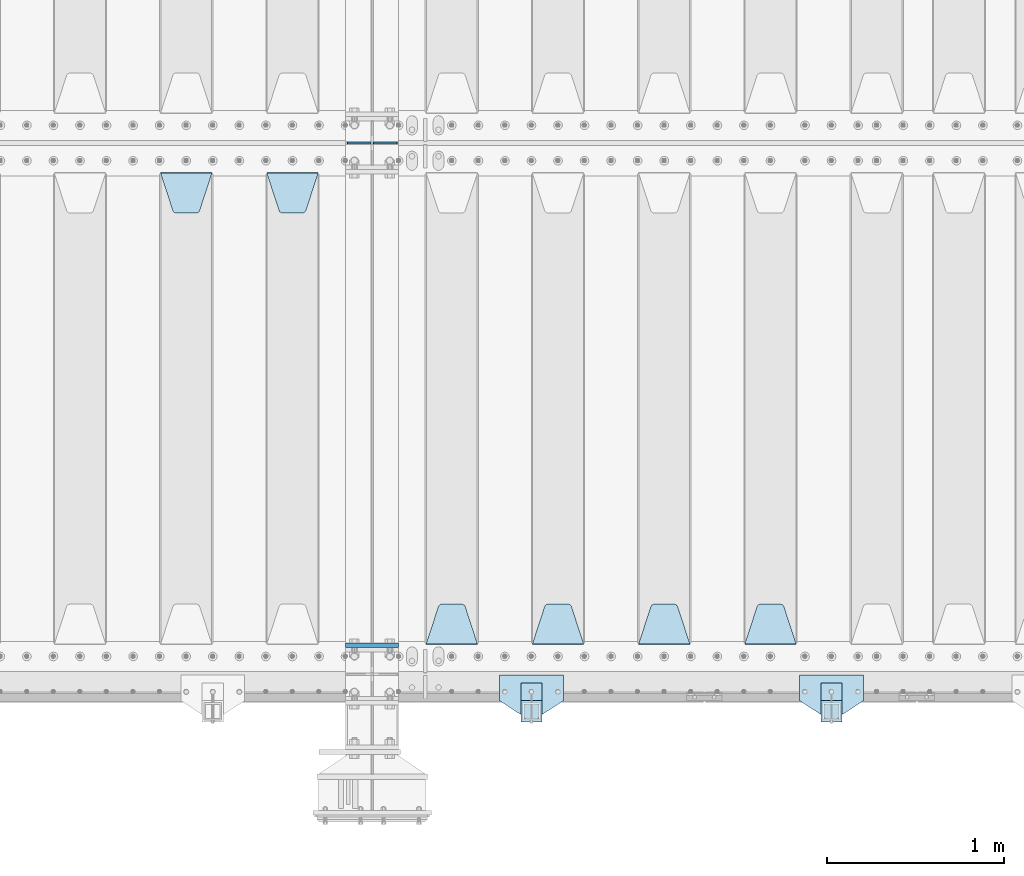
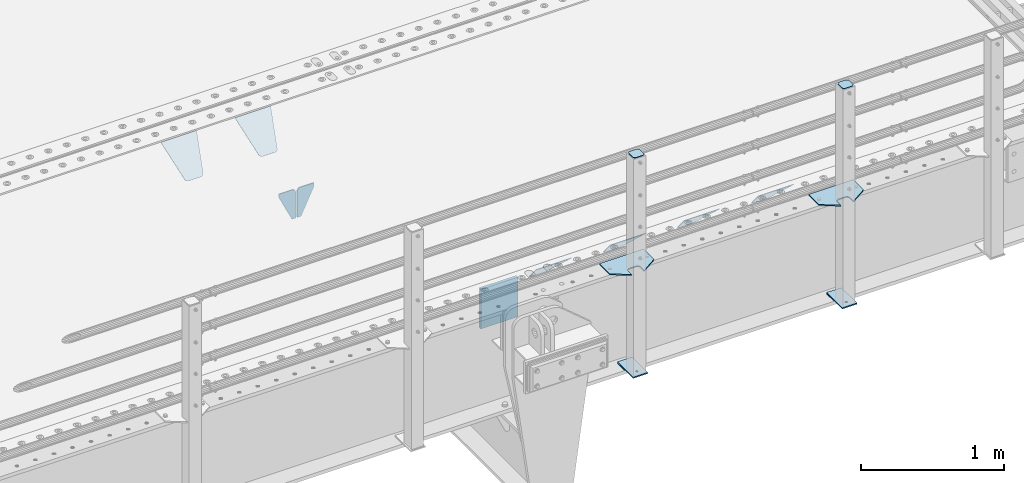
# One storey, part 212 of 257: 17 plates.
"""IFC2X3 building model written with IfcOpenShell, lengths in millimetres."""

import ifcopenshell
import ifcopenshell.guid

model = None  # the IFC model being written
_history = None  # IfcOwnerHistory: only IFC2X3 demands one
_inside = {}  # id of a spatial element -> (the spatial element, [elements in it])
_under = {}  # id of a project, library or spatial element -> (it, [spatial elements below it])
_declared = {}  # id of a project -> (the project, [libraries it declares])
_typed = {}  # id of a type object -> (the type object, [elements of that type])
_made_of = {}  # id of a material, layer set ... -> (it, [elements and type objects made of it])


def new_model(schema):
    """Start an empty IFC model of exactly this schema.

    Asked for "IFC4X3", IfcOpenShell would pick the latest addendum, in which some entities
    have other attributes; the version numbers below select the first issue.
    IFC2X3 requires an IfcOwnerHistory on every rooted entity: one is made here for all.
    """
    global model, _history
    if schema == "IFC4X3":
        model = ifcopenshell.file(schema_version=(4, 3, 0, 0))
    else:
        model = ifcopenshell.file(schema=schema)
    _inside.clear()
    _under.clear()
    _declared.clear()
    _typed.clear()
    _made_of.clear()
    _history = None
    if model.schema == "IFC2X3":
        org = make("IfcOrganization", Name="unknown")
        user = make(
            "IfcPersonAndOrganization",
            ThePerson=make("IfcPerson", FamilyName="unknown"),
            TheOrganization=org,
        )
        app = make(
            "IfcApplication",
            ApplicationDeveloper=org,
            Version="unknown",
            ApplicationFullName="unknown",
            ApplicationIdentifier="unknown",
        )
        _history = make(
            "IfcOwnerHistory",
            OwningUser=user,
            OwningApplication=app,
            ChangeAction="ADDED",
            CreationDate=0,
        )
    return model


def make(cls, **values):
    """One entity of the class cls with the attributes given. An attribute that is None is left unset."""
    return model.create_entity(
        cls, **{name: value for name, value in values.items() if value is not None}
    )


def rooted(cls, **values):
    """An entity with a GlobalId (a new one), such as an element, a storey or a relation."""
    return make(cls, GlobalId=ifcopenshell.guid.new(), OwnerHistory=_history, **values)


def si_unit(unit_type, name, prefix=None):
    """IfcSIUnit, for example si_unit("LENGTHUNIT", "METRE", prefix="MILLI")."""
    return make("IfcSIUnit", UnitType=unit_type, Prefix=prefix, Name=name)


def assignment(units):
    """IfcUnitAssignment: the units of a project."""
    return None if units is None else make("IfcUnitAssignment", Units=units)


def point(xyz):
    """IfcCartesianPoint."""
    return None if xyz is None else make("IfcCartesianPoint", Coordinates=xyz)


def direction(xyz):
    """IfcDirection."""
    return None if xyz is None else make("IfcDirection", DirectionRatios=xyz)


def frame(location, z_axis=None, x_axis=None):
    """IfcAxis2Placement3D, a coordinate frame: its origin and axes. An axis left out is left unset."""
    return make(
        "IfcAxis2Placement3D",
        Location=point(location),
        Axis=direction(z_axis),
        RefDirection=direction(x_axis),
    )


def origin_with_axes():
    """The frame at (0, 0, 0) with the z axis (0, 0, 1) and the x axis (1, 0, 0) written out."""
    return frame((0.0, 0.0, 0.0), z_axis=(0.0, 0.0, 1.0), x_axis=(1.0, 0.0, 0.0))


def place(relative_to, where):
    """IfcLocalPlacement: puts the frame where relative to a parent placement (None: the world)."""
    return make(
        "IfcLocalPlacement", PlacementRelTo=relative_to, RelativePlacement=where
    )


def context(
    kind, dimensions, precision=None, world=None, true_north=None, identifier=None
):
    """IfcGeometricRepresentationContext, for example the 3D "Model" context."""
    return make(
        "IfcGeometricRepresentationContext",
        ContextIdentifier=identifier,
        ContextType=kind,
        CoordinateSpaceDimension=dimensions,
        Precision=precision,
        WorldCoordinateSystem=world,
        TrueNorth=true_north,
    )


def subcontext(parent, identifier, kind, view, scale=None):
    """IfcGeometricRepresentationSubContext, for example "Body" below "Model"."""
    return make(
        "IfcGeometricRepresentationSubContext",
        ContextIdentifier=identifier,
        ContextType=kind,
        ParentContext=parent,
        TargetScale=scale,
        TargetView=view,
    )


def project(units=None, contexts=None):
    """IfcProject with its units and contexts."""
    return rooted(
        "IfcProject",
        Name="project",
        RepresentationContexts=contexts,
        UnitsInContext=assignment(units),
    )


def spatial(cls, under=None, at=None, **own):
    """A site, building, storey or space (cls), placed at a placement, below another one or the project."""
    s = rooted(cls, ObjectPlacement=at, **own)
    if under is not None:
        _under.setdefault(under.id(), (under, []))[1].append(s)
    return s


def faces_of(points, faces, orient=None, outer=None):
    """IfcFace entities. A face is a list of loops; a loop is a list of indices into points, from 0.

    orient and outer hold one flag for each loop. By default every Orientation is true, the
    first loop of a face is its IfcFaceOuterBound and the others are IfcFaceBound.
    """
    made = []
    for i, loops in enumerate(faces):
        bounds = []
        for j, loop in enumerate(loops):
            is_outer = j == 0 if outer is None else outer[i][j]
            bounds.append(
                make(
                    "IfcFaceOuterBound" if is_outer else "IfcFaceBound",
                    Bound=make("IfcPolyLoop", Polygon=[points[k] for k in loop]),
                    Orientation=True if orient is None else orient[i][j],
                )
            )
        made.append(make("IfcFace", Bounds=bounds))
    return made


def faceted_brep(points, faces, orient=None, outer=None, voids=None):
    """IfcFacetedBrep: a solid bounded by flat faces; with voids (closed shells), ...WithVoids."""
    shared = [point(p) for p in points]
    hull = make("IfcClosedShell", CfsFaces=faces_of(shared, faces, orient, outer))
    if voids is None:
        return make("IfcFacetedBrep", Outer=hull)
    return make(
        "IfcFacetedBrepWithVoids",
        Outer=hull,
        Voids=[
            make(cls, CfsFaces=faces_of(shared, fs, o, b)) for cls, fs, o, b in voids
        ],
    )


def shape(context_of_items, identifier, shape_type, items):
    """IfcShapeRepresentation: the items that make up one representation, for example the "Body"."""
    return make(
        "IfcShapeRepresentation",
        ContextOfItems=context_of_items,
        RepresentationIdentifier=identifier,
        RepresentationType=shape_type,
        Items=items,
    )


def material(Name=None, Category=None):
    """IfcMaterial."""
    return make("IfcMaterial", Name=Name, Category=Category)


def made_of(thing, what):
    """Note that an element or type object is made of a material, layer set ...; save() writes the relation."""
    if what is not None:
        _made_of.setdefault(what.id(), (what, []))[1].append(thing)
    return thing


def type_object(cls, material=None, **own):
    """A type object (cls), such as IfcWallType, which elements share."""
    return made_of(rooted(cls, **own), material)


def element(
    cls,
    number,
    at=None,
    inside=None,
    cuts=None,
    type_object=None,
    material=None,
    context=None,
    identifier="Body",
    shape_type=None,
    held_by="IfcProductDefinitionShape",
    body=None,
    shapes=None,
    **own,
):
    """One element of the class cls, such as IfcWall. Its Tag is "e" and its number.

    at: its placement. inside: the storey or other place that contains it. cuts: it is an
    opening in that element (IfcRelVoidsElement). A single representation is given by context,
    identifier, shape_type and body (its items); several are given by shapes. held_by: the class
    of the entity that holds the representations. save() writes the other relations.
    """
    e = rooted(cls, Tag="e%d" % number, ObjectPlacement=at, **own)
    if body is not None:
        shapes = [shape(context, identifier, shape_type, body)]
    if shapes is not None:
        e.Representation = make(held_by, Representations=shapes)
    if inside is not None:
        _inside.setdefault(inside.id(), (inside, []))[1].append(e)
    if cuts is not None:
        rooted(
            "IfcRelVoidsElement", RelatingBuildingElement=cuts, RelatedOpeningElement=e
        )
    if type_object is not None:
        _typed.setdefault(type_object.id(), (type_object, []))[1].append(e)
    return made_of(e, material)


def aggregate(whole, parts):
    """IfcRelAggregates: a whole, such as a stair, and the parts it consists of."""
    return rooted("IfcRelAggregates", RelatingObject=whole, RelatedObjects=parts)


def save(model, path):
    """Write the relations noted so far, then the file.

    IfcRelAggregates (storeys below a building ...), IfcRelContainedInSpatialStructure (elements
    in a storey), IfcRelDefinesByType, IfcRelAssociatesMaterial and IfcRelDeclares: one each for
    every whole, place, type object, material and project.
    """
    for whole, parts in _under.values():
        aggregate(whole, parts)
    for where, things in _inside.values():
        rooted(
            "IfcRelContainedInSpatialStructure",
            RelatedElements=things,
            RelatingStructure=where,
        )
    for kind, things in _typed.values():
        rooted("IfcRelDefinesByType", RelatedObjects=things, RelatingType=kind)
    for what, things in _made_of.values():
        rooted("IfcRelAssociatesMaterial", RelatedObjects=things, RelatingMaterial=what)
    for by, libraries in _declared.values():
        rooted("IfcRelDeclares", RelatingContext=by, RelatedDefinitions=libraries)
    model.write(path)


model = new_model("IFC2X3")

# Units and contexts
model_context = context("Model", 3, precision=1e-05, world=origin_with_axes())
body_context = subcontext(model_context, "Body", "Model", "MODEL_VIEW")
ifc_project = project(units=[si_unit("LENGTHUNIT", "METRE", prefix="MILLI"), si_unit("AREAUNIT", "SQUARE_METRE"), si_unit("VOLUMEUNIT", "CUBIC_METRE"), si_unit("MASSUNIT", "GRAM", prefix="KILO"), si_unit("TIMEUNIT", "SECOND"), si_unit("PLANEANGLEUNIT", "RADIAN"), si_unit("SOLIDANGLEUNIT", "STERADIAN"), si_unit("THERMODYNAMICTEMPERATUREUNIT", "DEGREE_CELSIUS"), si_unit("LUMINOUSINTENSITYUNIT", "LUMEN")], contexts=[model_context])

# Site, building, storey
site_placement = place(None, origin_with_axes())
site = spatial("IfcSite", under=ifc_project, at=site_placement, CompositionType="ELEMENT")
building_placement = place(site_placement, origin_with_axes())
building = spatial("IfcBuilding", under=site, at=building_placement, Name="Standard", CompositionType="ELEMENT")
storey_placement = place(building_placement, origin_with_axes())
storey = spatial("IfcBuildingStorey", under=building, at=storey_placement, Name="Undefined", CompositionType="ELEMENT", Elevation=0.0)

# Plates
ifc_material_1 = material(Name="STEEL/S355N")
plate_type_1 = type_object("IfcPlateType", PredefinedType="NOTDEFINED")
plate_1_placement = place(storey_placement, frame((54550.0, 162.5, -340.000000000044), z_axis=(0.0, 0.0, 1.0), x_axis=(1.0, 0.0, 0.0)))
element("IfcPlate", 1, at=plate_1_placement, inside=storey, type_object=plate_type_1, material=ifc_material_1, context=body_context, shape_type="Brep", body=[
    faceted_brep([(0.0, -12.5, 0.0), (0.0, -12.5, 340.0), (0.0, 12.5, 340.0), (0.0, 12.5, 0.0), (300.0, -12.5, 340.0), (300.0, 12.5, 340.0), (300.0, -12.5, 0.0), (300.0, 12.5, 0.0)], [[[0, 1, 2, 3]], [[1, 4, 5, 2]], [[4, 6, 7, 5]], [[6, 0, 3, 7]], [[5, 7, 3, 2]], [[6, 4, 1, 0]]]),
])
plate_type_2 = type_object("IfcPlateType", PredefinedType="NOTDEFINED")
for number, where, z_axis, x_axis in (
    (2, (54693.4999999989, 3000.00000000422, -915.000019536855), (0.0, 0.0, -1.0), (-1.0, 0.0, 0.0)),
    (3, (54706.4999999991, 3000.0000000042, -915.000019536856), (0.0, 0.0, -1.0), (1.0, 0.0, 0.0)),
):
    element("IfcPlate", number, at=place(storey_placement, frame(where, z_axis=z_axis, x_axis=x_axis)), inside=storey, type_object=plate_type_2, material=ifc_material_1, context=body_context, shape_type="Brep", body=[
        faceted_brep([(0.0, -5.0, 27.0), (0.0, -5.0, 250.0), (0.0, 5.0, 250.0), (0.0, 5.0, 27.0), (30.0, -5.0, 250.0), (30.0, 5.0, 250.0), (135.0, -5.0, 30.0), (135.0, 5.0, 30.0), (135.0, -5.0, 0.0), (135.0, 5.0, 0.0), (27.0, -5.0, 0.0), (27.0, 5.0, 0.0), (22.311499202995, -5.0, 0.410190668670339), (22.311499202995, 5.0, 0.410190668670339), (17.7654561302043, -5.0, 1.62829923878053), (17.7654561302043, 5.0, 1.62829923878053), (13.5, -5.0, 3.6173140978201), (13.5, 5.0, 3.6173140978201), (9.64473453846585, -5.0, 6.31680003578754), (9.64473453846585, 5.0, 6.31680003578754), (6.31680003579095, -5.0, 9.64473453846347), (6.31680003579095, 5.0, 9.64473453846347), (3.61731409782078, -5.0, 13.5), (3.61731409782078, 5.0, 13.5), (1.62829923877871, -5.0, 17.765456130207), (1.62829923877871, 5.0, 17.765456130207), (0.410190668670111, -5.0, 22.3114992029929), (0.410190668670111, 5.0, 22.3114992029929)], [[[0, 1, 2, 3]], [[1, 4, 5, 2]], [[4, 6, 7, 5]], [[6, 8, 9, 7]], [[8, 10, 11, 9]], [[10, 12, 13, 11]], [[12, 14, 15, 13]], [[14, 16, 17, 15]], [[16, 18, 19, 17]], [[18, 20, 21, 19]], [[20, 22, 23, 21]], [[22, 24, 25, 23]], [[24, 26, 27, 25]], [[26, 0, 3, 27]], [[5, 7, 9, 11, 13, 15, 17, 19, 21, 23, 25, 27, 3, 2]], [[26, 24, 22, 20, 18, 16, 14, 12, 10, 8, 6, 4, 1, 0]]]),
    ])
plate_type_3 = type_object("IfcPlateType", PredefinedType="NOTDEFINED")
plate_2_placement = place(storey_placement, frame((57095.0, 168.232233047035, -1.76776695296758), z_axis=(0.0, 0.707106781186547, -0.707106781186548), x_axis=(-1.0, 0.0, 0.0)))
element("IfcPlate", 4, at=plate_2_placement, inside=storey, type_object=plate_type_3, material=ifc_material_1, context=body_context, shape_type="Brep", body=[
    faceted_brep([(0.0, -2.5, 0.0), (69.345504679477, -2.50000000000091, 300.17173142483), (69.345504679477, 2.5, 300.171731424831), (0.0, 2.5, 0.0), (70.927406119954, -2.50000000000091, 304.8974424154), (70.927406119954, 2.5, 304.8974424154), (73.3818627772271, -2.50000000000091, 309.234538108527), (73.3818627772271, 2.49999999999909, 309.234538108527), (76.6187032999587, -2.5, 313.023683126103), (76.6187032999587, 2.5, 313.023683126103), (80.5190132705029, -2.5, 316.125672595372), (80.5190132705029, 2.5, 316.125672595371), (84.9395038596849, -2.5, 318.426546230476), (84.9395038596849, 2.5, 318.426546230477), (89.7177759439219, -2.5, 319.841774983275), (89.7177759439219, 2.5, 319.841774983275), (94.6782862926484, -2.5, 320.319366455079), (94.6782862926484, 2.5, 320.319366455079), (195.321713707352, -2.5, 320.319366455079), (195.321713707352, 2.5, 320.319366455079), (200.282224056078, -2.5, 319.841774983275), (200.282224056078, 2.49999999999909, 319.841774983275), (205.060496140315, -2.5, 318.426546230476), (205.060496140315, 2.49999999999909, 318.426546230475), (209.480986729497, -2.5, 316.125672595371), (209.480986729497, 2.5, 316.125672595371), (213.381296700041, -2.50000000000091, 313.023683126102), (213.381296700041, 2.5, 313.023683126103), (216.618137222766, -2.50000000000091, 309.234538108527), (216.618137222766, 2.5, 309.234538108527), (219.072593880039, -2.5, 304.897442415399), (219.072593880039, 2.5, 304.897442415399), (220.654495320523, -2.50000000000091, 300.17173142483), (220.654495320523, 2.5, 300.171731424831), (290.0, -2.50000000000091, 0.0), (290.0, 2.5, 9.09494701772928e-13)], [[[0, 1, 2, 3]], [[1, 4, 5, 2]], [[4, 6, 7, 5]], [[6, 8, 9, 7]], [[8, 10, 11, 9]], [[10, 12, 13, 11]], [[12, 14, 15, 13]], [[14, 16, 17, 15]], [[16, 18, 19, 17]], [[18, 20, 21, 19]], [[20, 22, 23, 21]], [[22, 24, 25, 23]], [[24, 26, 27, 25]], [[26, 28, 29, 27]], [[28, 30, 31, 29]], [[30, 32, 33, 31]], [[32, 34, 35, 33]], [[34, 0, 3, 35]], [[5, 7, 9, 11, 13, 15, 17, 19, 21, 23, 25, 27, 29, 31, 33, 35, 3, 2]], [[34, 32, 30, 28, 26, 24, 22, 20, 18, 16, 14, 12, 10, 8, 6, 4, 1, 0]]]),
])
plate_3_placement = place(storey_placement, frame((56495.0, 168.232233047035, -1.76776695296758), z_axis=(0.0, 0.707106781186547, -0.707106781186548), x_axis=(-1.0, 0.0, 0.0)))
element("IfcPlate", 5, at=plate_3_placement, inside=storey, type_object=plate_type_3, material=ifc_material_1, context=body_context, shape_type="Brep", body=[
    faceted_brep([(0.0, -2.5, 0.0), (69.345504679477, -2.50000000000091, 300.17173142483), (69.345504679477, 2.5, 300.171731424831), (0.0, 2.5, 0.0), (70.927406119954, -2.50000000000091, 304.8974424154), (70.927406119954, 2.5, 304.8974424154), (73.3818627772271, -2.50000000000091, 309.234538108527), (73.3818627772271, 2.49999999999909, 309.234538108527), (76.6187032999587, -2.5, 313.023683126103), (76.6187032999587, 2.5, 313.023683126103), (80.5190132705029, -2.5, 316.125672595372), (80.5190132705029, 2.5, 316.125672595371), (84.9395038596849, -2.5, 318.426546230476), (84.9395038596849, 2.5, 318.426546230477), (89.7177759439219, -2.5, 319.841774983275), (89.7177759439219, 2.5, 319.841774983275), (94.6782862926484, -2.5, 320.319366455079), (94.6782862926484, 2.5, 320.319366455079), (195.321713707352, -2.5, 320.319366455079), (195.321713707352, 2.5, 320.319366455079), (200.282224056078, -2.5, 319.841774983275), (200.282224056078, 2.49999999999909, 319.841774983275), (205.060496140315, -2.5, 318.426546230476), (205.060496140315, 2.49999999999909, 318.426546230475), (209.480986729497, -2.5, 316.125672595371), (209.480986729497, 2.5, 316.125672595371), (213.381296700041, -2.50000000000091, 313.023683126102), (213.381296700041, 2.5, 313.023683126103), (216.618137222766, -2.50000000000091, 309.234538108527), (216.618137222766, 2.5, 309.234538108527), (219.072593880039, -2.5, 304.897442415399), (219.072593880039, 2.5, 304.897442415399), (220.654495320523, -2.50000000000091, 300.17173142483), (220.654495320523, 2.5, 300.171731424831), (290.0, -2.50000000000091, 0.0), (290.0, 2.5, 9.09494701772928e-13)], [[[0, 1, 2, 3]], [[1, 4, 5, 2]], [[4, 6, 7, 5]], [[6, 8, 9, 7]], [[8, 10, 11, 9]], [[10, 12, 13, 11]], [[12, 14, 15, 13]], [[14, 16, 17, 15]], [[16, 18, 19, 17]], [[18, 20, 21, 19]], [[20, 22, 23, 21]], [[22, 24, 25, 23]], [[24, 26, 27, 25]], [[26, 28, 29, 27]], [[28, 30, 31, 29]], [[30, 32, 33, 31]], [[32, 34, 35, 33]], [[34, 0, 3, 35]], [[5, 7, 9, 11, 13, 15, 17, 19, 21, 23, 25, 27, 29, 31, 33, 35, 3, 2]], [[34, 32, 30, 28, 26, 24, 22, 20, 18, 16, 14, 12, 10, 8, 6, 4, 1, 0]]]),
])
plate_4_placement = place(storey_placement, frame((55895.0, 168.232233047035, -1.76776695296758), z_axis=(0.0, 0.707106781186547, -0.707106781186548), x_axis=(-1.0, 0.0, 0.0)))
element("IfcPlate", 6, at=plate_4_placement, inside=storey, type_object=plate_type_3, material=ifc_material_1, context=body_context, shape_type="Brep", body=[
    faceted_brep([(0.0, -2.5, 0.0), (69.345504679477, -2.50000000000091, 300.17173142483), (69.345504679477, 2.5, 300.171731424831), (0.0, 2.5, 0.0), (70.927406119954, -2.50000000000091, 304.8974424154), (70.927406119954, 2.5, 304.8974424154), (73.3818627772271, -2.50000000000091, 309.234538108527), (73.3818627772271, 2.49999999999909, 309.234538108527), (76.6187032999587, -2.5, 313.023683126103), (76.6187032999587, 2.5, 313.023683126103), (80.5190132705029, -2.5, 316.125672595372), (80.5190132705029, 2.5, 316.125672595371), (84.9395038596849, -2.5, 318.426546230476), (84.9395038596849, 2.5, 318.426546230477), (89.7177759439219, -2.5, 319.841774983275), (89.7177759439219, 2.5, 319.841774983275), (94.6782862926484, -2.5, 320.319366455079), (94.6782862926484, 2.5, 320.319366455079), (195.321713707352, -2.5, 320.319366455079), (195.321713707352, 2.5, 320.319366455079), (200.282224056078, -2.5, 319.841774983275), (200.282224056078, 2.49999999999909, 319.841774983275), (205.060496140315, -2.5, 318.426546230476), (205.060496140315, 2.49999999999909, 318.426546230475), (209.480986729497, -2.5, 316.125672595371), (209.480986729497, 2.5, 316.125672595371), (213.381296700041, -2.50000000000091, 313.023683126102), (213.381296700041, 2.5, 313.023683126103), (216.618137222766, -2.50000000000091, 309.234538108527), (216.618137222766, 2.5, 309.234538108527), (219.072593880039, -2.5, 304.897442415399), (219.072593880039, 2.5, 304.897442415399), (220.654495320523, -2.50000000000091, 300.17173142483), (220.654495320523, 2.5, 300.171731424831), (290.0, -2.50000000000091, 0.0), (290.0, 2.5, 9.09494701772928e-13)], [[[0, 1, 2, 3]], [[1, 4, 5, 2]], [[4, 6, 7, 5]], [[6, 8, 9, 7]], [[8, 10, 11, 9]], [[10, 12, 13, 11]], [[12, 14, 15, 13]], [[14, 16, 17, 15]], [[16, 18, 19, 17]], [[18, 20, 21, 19]], [[20, 22, 23, 21]], [[22, 24, 25, 23]], [[24, 26, 27, 25]], [[26, 28, 29, 27]], [[28, 30, 31, 29]], [[30, 32, 33, 31]], [[32, 34, 35, 33]], [[34, 0, 3, 35]], [[5, 7, 9, 11, 13, 15, 17, 19, 21, 23, 25, 27, 29, 31, 33, 35, 3, 2]], [[34, 32, 30, 28, 26, 24, 22, 20, 18, 16, 14, 12, 10, 8, 6, 4, 1, 0]]]),
])
plate_5_placement = place(storey_placement, frame((55295.0, 168.232233047035, -1.76776695296758), z_axis=(0.0, 0.707106781186547, -0.707106781186548), x_axis=(-1.0, 0.0, 0.0)))
element("IfcPlate", 7, at=plate_5_placement, inside=storey, type_object=plate_type_3, material=ifc_material_1, context=body_context, shape_type="Brep", body=[
    faceted_brep([(0.0, -2.5, 0.0), (69.345504679477, -2.50000000000091, 300.17173142483), (69.345504679477, 2.5, 300.171731424831), (0.0, 2.5, 0.0), (70.927406119954, -2.50000000000091, 304.8974424154), (70.927406119954, 2.5, 304.8974424154), (73.3818627772271, -2.50000000000091, 309.234538108527), (73.3818627772271, 2.49999999999909, 309.234538108527), (76.6187032999587, -2.5, 313.023683126103), (76.6187032999587, 2.5, 313.023683126103), (80.5190132705029, -2.5, 316.125672595372), (80.5190132705029, 2.5, 316.125672595371), (84.9395038596849, -2.5, 318.426546230476), (84.9395038596849, 2.5, 318.426546230477), (89.7177759439219, -2.5, 319.841774983275), (89.7177759439219, 2.5, 319.841774983275), (94.6782862926484, -2.5, 320.319366455079), (94.6782862926484, 2.5, 320.319366455079), (195.321713707352, -2.5, 320.319366455079), (195.321713707352, 2.5, 320.319366455079), (200.282224056078, -2.5, 319.841774983275), (200.282224056078, 2.49999999999909, 319.841774983275), (205.060496140315, -2.5, 318.426546230476), (205.060496140315, 2.49999999999909, 318.426546230475), (209.480986729497, -2.5, 316.125672595371), (209.480986729497, 2.5, 316.125672595371), (213.381296700041, -2.50000000000091, 313.023683126102), (213.381296700041, 2.5, 313.023683126103), (216.618137222766, -2.50000000000091, 309.234538108527), (216.618137222766, 2.5, 309.234538108527), (219.072593880039, -2.5, 304.897442415399), (219.072593880039, 2.5, 304.897442415399), (220.654495320523, -2.50000000000091, 300.17173142483), (220.654495320523, 2.5, 300.171731424831), (290.0, -2.50000000000091, 0.0), (290.0, 2.5, 9.09494701772928e-13)], [[[0, 1, 2, 3]], [[1, 4, 5, 2]], [[4, 6, 7, 5]], [[6, 8, 9, 7]], [[8, 10, 11, 9]], [[10, 12, 13, 11]], [[12, 14, 15, 13]], [[14, 16, 17, 15]], [[16, 18, 19, 17]], [[18, 20, 21, 19]], [[20, 22, 23, 21]], [[22, 24, 25, 23]], [[24, 26, 27, 25]], [[26, 28, 29, 27]], [[28, 30, 31, 29]], [[30, 32, 33, 31]], [[32, 34, 35, 33]], [[34, 0, 3, 35]], [[5, 7, 9, 11, 13, 15, 17, 19, 21, 23, 25, 27, 29, 31, 33, 35, 3, 2]], [[34, 32, 30, 28, 26, 24, 22, 20, 18, 16, 14, 12, 10, 8, 6, 4, 1, 0]]]),
])
plate_6_placement = place(storey_placement, frame((54105.0, 2831.76776695594, -1.767766952965), z_axis=(0.0, -0.707106781186548, -0.707106781186547), x_axis=(1.0, 0.0, 0.0)))
element("IfcPlate", 8, at=plate_6_placement, inside=storey, type_object=plate_type_3, material=ifc_material_1, context=body_context, shape_type="Brep", body=[
    faceted_brep([(0.0, -2.5, 0.0), (69.345504679477, -2.50000000000091, 300.17173142483), (69.345504679477, 2.5, 300.171731424831), (0.0, 2.5, 0.0), (70.927406119954, -2.50000000000091, 304.8974424154), (70.927406119954, 2.5, 304.8974424154), (73.3818627772271, -2.50000000000091, 309.234538108527), (73.3818627772271, 2.49999999999909, 309.234538108527), (76.6187032999587, -2.5, 313.023683126103), (76.6187032999587, 2.5, 313.023683126103), (80.5190132705029, -2.5, 316.125672595372), (80.5190132705029, 2.5, 316.125672595371), (84.9395038596849, -2.5, 318.426546230476), (84.9395038596849, 2.5, 318.426546230477), (89.7177759439219, -2.5, 319.841774983275), (89.7177759439219, 2.5, 319.841774983275), (94.6782862926484, -2.5, 320.319366455079), (94.6782862926484, 2.5, 320.319366455079), (195.321713707352, -2.5, 320.319366455079), (195.321713707352, 2.5, 320.319366455079), (200.282224056078, -2.5, 319.841774983275), (200.282224056078, 2.49999999999909, 319.841774983275), (205.060496140315, -2.5, 318.426546230476), (205.060496140315, 2.49999999999909, 318.426546230475), (209.480986729497, -2.5, 316.125672595371), (209.480986729497, 2.5, 316.125672595371), (213.381296700041, -2.50000000000091, 313.023683126102), (213.381296700041, 2.5, 313.023683126103), (216.618137222766, -2.50000000000091, 309.234538108527), (216.618137222766, 2.5, 309.234538108527), (219.072593880039, -2.5, 304.897442415399), (219.072593880039, 2.5, 304.897442415399), (220.654495320523, -2.50000000000091, 300.17173142483), (220.654495320523, 2.5, 300.171731424831), (290.0, -2.50000000000091, 0.0), (290.0, 2.5, 9.09494701772928e-13)], [[[0, 1, 2, 3]], [[1, 4, 5, 2]], [[4, 6, 7, 5]], [[6, 8, 9, 7]], [[8, 10, 11, 9]], [[10, 12, 13, 11]], [[12, 14, 15, 13]], [[14, 16, 17, 15]], [[16, 18, 19, 17]], [[18, 20, 21, 19]], [[20, 22, 23, 21]], [[22, 24, 25, 23]], [[24, 26, 27, 25]], [[26, 28, 29, 27]], [[28, 30, 31, 29]], [[30, 32, 33, 31]], [[32, 34, 35, 33]], [[34, 0, 3, 35]], [[5, 7, 9, 11, 13, 15, 17, 19, 21, 23, 25, 27, 29, 31, 33, 35, 3, 2]], [[34, 32, 30, 28, 26, 24, 22, 20, 18, 16, 14, 12, 10, 8, 6, 4, 1, 0]]]),
])
plate_7_placement = place(storey_placement, frame((53505.0, 2831.76776695594, -1.767766952965), z_axis=(0.0, -0.707106781186548, -0.707106781186547), x_axis=(1.0, 0.0, 0.0)))
element("IfcPlate", 9, at=plate_7_placement, inside=storey, type_object=plate_type_3, material=ifc_material_1, context=body_context, shape_type="Brep", body=[
    faceted_brep([(0.0, -2.5, 0.0), (69.345504679477, -2.50000000000091, 300.17173142483), (69.345504679477, 2.5, 300.171731424831), (0.0, 2.5, 0.0), (70.927406119954, -2.50000000000091, 304.8974424154), (70.927406119954, 2.5, 304.8974424154), (73.3818627772271, -2.50000000000091, 309.234538108527), (73.3818627772271, 2.49999999999909, 309.234538108527), (76.6187032999587, -2.5, 313.023683126103), (76.6187032999587, 2.5, 313.023683126103), (80.5190132705029, -2.5, 316.125672595372), (80.5190132705029, 2.5, 316.125672595371), (84.9395038596849, -2.5, 318.426546230476), (84.9395038596849, 2.5, 318.426546230477), (89.7177759439219, -2.5, 319.841774983275), (89.7177759439219, 2.5, 319.841774983275), (94.6782862926484, -2.5, 320.319366455079), (94.6782862926484, 2.5, 320.319366455079), (195.321713707352, -2.5, 320.319366455079), (195.321713707352, 2.5, 320.319366455079), (200.282224056078, -2.5, 319.841774983275), (200.282224056078, 2.49999999999909, 319.841774983275), (205.060496140315, -2.5, 318.426546230476), (205.060496140315, 2.49999999999909, 318.426546230475), (209.480986729497, -2.5, 316.125672595371), (209.480986729497, 2.5, 316.125672595371), (213.381296700041, -2.50000000000091, 313.023683126102), (213.381296700041, 2.5, 313.023683126103), (216.618137222766, -2.50000000000091, 309.234538108527), (216.618137222766, 2.5, 309.234538108527), (219.072593880039, -2.5, 304.897442415399), (219.072593880039, 2.5, 304.897442415399), (220.654495320523, -2.50000000000091, 300.17173142483), (220.654495320523, 2.5, 300.171731424831), (290.0, -2.50000000000091, 0.0), (290.0, 2.5, 9.09494701772928e-13)], [[[0, 1, 2, 3]], [[1, 4, 5, 2]], [[4, 6, 7, 5]], [[6, 8, 9, 7]], [[8, 10, 11, 9]], [[10, 12, 13, 11]], [[12, 14, 15, 13]], [[14, 16, 17, 15]], [[16, 18, 19, 17]], [[18, 20, 21, 19]], [[20, 22, 23, 21]], [[22, 24, 25, 23]], [[24, 26, 27, 25]], [[26, 28, 29, 27]], [[28, 30, 31, 29]], [[30, 32, 33, 31]], [[32, 34, 35, 33]], [[34, 0, 3, 35]], [[5, 7, 9, 11, 13, 15, 17, 19, 21, 23, 25, 27, 29, 31, 33, 35, 3, 2]], [[34, 32, 30, 28, 26, 24, 22, 20, 18, 16, 14, 12, 10, 8, 6, 4, 1, 0]]]),
])
ifc_material_2 = material(Name="STEEL/S355J2")
plate_type_4 = type_object("IfcPlateType", PredefinedType="NOTDEFINED")
plate_8_placement = place(storey_placement, frame((57475.0, -4.99999999999636, 5.00000000004911), z_axis=(0.0, -1.0, 0.0), x_axis=(-1.0, 0.0, 0.0)))
element("IfcPlate", 10, at=plate_8_placement, inside=storey, type_object=plate_type_4, material=ifc_material_2, context=body_context, shape_type="Brep", body=[
    faceted_brep([(0.0, -5.0, 0.0), (2.31396552408114e-06, -5.0, 145.0), (2.31396552408114e-06, 5.0, 145.0), (0.0, 5.0, 0.0), (130.0, -5.0, 230.0), (130.0, 5.0, 230.0), (130.0, -5.0, 180.0), (130.0, 5.0, 180.0), (130.48036798992, -5.0, 175.122741949597), (130.48036798992, 5.0, 175.122741949597), (131.903011687216, -5.0, 170.432914190873), (131.903011687216, 5.0, 170.432914190873), (134.213259692435, -5.0, 166.11074417451), (134.213259692435, 5.0, 166.11074417451), (137.322330470335, -5.0, 162.322330470337), (137.322330470335, 5.0, 162.322330470337), (141.110744174512, -5.0, 159.213259692437), (141.110744174512, 5.0, 159.213259692437), (145.432914190875, -5.0, 156.903011687218), (145.432914190875, 5.0, 156.903011687218), (150.122741949599, -5.0, 155.48036798992), (150.122741949599, 5.0, 155.48036798992), (155.0, -5.0, 155.0), (155.0, 5.0, 155.0), (205.0, -5.0, 155.0), (205.0, 5.0, 155.0), (209.877258050401, -5.0, 155.48036798992), (209.877258050401, 5.0, 155.48036798992), (214.567085809125, -5.0, 156.903011687218), (214.567085809125, 5.0, 156.903011687218), (218.889255825488, -5.0, 159.213259692437), (218.889255825488, 5.0, 159.213259692437), (222.677669529665, -5.0, 162.322330470337), (222.677669529665, 5.0, 162.322330470337), (225.786740307565, -5.0, 166.11074417451), (225.786740307565, 5.0, 166.11074417451), (228.096988312784, -5.0, 170.432914190873), (228.096988312784, 5.0, 170.432914190873), (229.51963201008, -5.0, 175.122741949597), (229.51963201008, 5.0, 175.122741949597), (230.0, -5.0, 180.0), (230.0, 5.0, 180.0), (230.0, -5.0, 230.0), (230.0, 5.0, 230.0), (360.0, -5.0, 145.0), (360.0, 5.0, 145.0), (360.0, -5.0, -7.27595761418343e-12), (360.0, 5.0, -7.27595761418343e-12)], [[[0, 1, 2, 3]], [[1, 4, 5, 2]], [[4, 6, 7, 5]], [[6, 8, 9, 7]], [[8, 10, 11, 9]], [[10, 12, 13, 11]], [[12, 14, 15, 13]], [[14, 16, 17, 15]], [[16, 18, 19, 17]], [[18, 20, 21, 19]], [[20, 22, 23, 21]], [[22, 24, 25, 23]], [[24, 26, 27, 25]], [[26, 28, 29, 27]], [[28, 30, 31, 29]], [[30, 32, 33, 31]], [[32, 34, 35, 33]], [[34, 36, 37, 35]], [[36, 38, 39, 37]], [[38, 40, 41, 39]], [[40, 42, 43, 41]], [[42, 44, 45, 43]], [[44, 46, 47, 45]], [[46, 0, 3, 47]], [[5, 7, 9, 11, 13, 15, 17, 19, 21, 23, 25, 27, 29, 31, 33, 35, 37, 39, 41, 43, 45, 47, 3, 2]], [[46, 44, 42, 40, 38, 36, 34, 32, 30, 28, 26, 24, 22, 20, 18, 16, 14, 12, 10, 8, 6, 4, 1, 0]]]),
])
plate_9_placement = place(storey_placement, frame((55780.0, -4.99999999999636, 5.00000000004911), z_axis=(0.0, -1.0, 0.0), x_axis=(-1.0, 0.0, 0.0)))
element("IfcPlate", 11, at=plate_9_placement, inside=storey, type_object=plate_type_4, material=ifc_material_2, context=body_context, shape_type="Brep", body=[
    faceted_brep([(0.0, -5.0, 0.0), (2.31396552408114e-06, -5.0, 145.0), (2.31396552408114e-06, 5.0, 145.0), (0.0, 5.0, 0.0), (130.0, -5.0, 230.0), (130.0, 5.0, 230.0), (130.0, -5.0, 180.0), (130.0, 5.0, 180.0), (130.48036798992, -5.0, 175.122741949597), (130.48036798992, 5.0, 175.122741949597), (131.903011687216, -5.0, 170.432914190873), (131.903011687216, 5.0, 170.432914190873), (134.213259692435, -5.0, 166.11074417451), (134.213259692435, 5.0, 166.11074417451), (137.322330470335, -5.0, 162.322330470337), (137.322330470335, 5.0, 162.322330470337), (141.110744174512, -5.0, 159.213259692437), (141.110744174512, 5.0, 159.213259692437), (145.432914190875, -5.0, 156.903011687218), (145.432914190875, 5.0, 156.903011687218), (150.122741949599, -5.0, 155.48036798992), (150.122741949599, 5.0, 155.48036798992), (155.0, -5.0, 155.0), (155.0, 5.0, 155.0), (205.0, -5.0, 155.0), (205.0, 5.0, 155.0), (209.877258050401, -5.0, 155.48036798992), (209.877258050401, 5.0, 155.48036798992), (214.567085809125, -5.0, 156.903011687218), (214.567085809125, 5.0, 156.903011687218), (218.889255825488, -5.0, 159.213259692437), (218.889255825488, 5.0, 159.213259692437), (222.677669529665, -5.0, 162.322330470337), (222.677669529665, 5.0, 162.322330470337), (225.786740307565, -5.0, 166.11074417451), (225.786740307565, 5.0, 166.11074417451), (228.096988312784, -5.0, 170.432914190873), (228.096988312784, 5.0, 170.432914190873), (229.51963201008, -5.0, 175.122741949597), (229.51963201008, 5.0, 175.122741949597), (230.0, -5.0, 180.0), (230.0, 5.0, 180.0), (230.0, -5.0, 230.0), (230.0, 5.0, 230.0), (360.0, -5.0, 145.0), (360.0, 5.0, 145.0), (360.0, -5.0, -7.27595761418343e-12), (360.0, 5.0, -7.27595761418343e-12)], [[[0, 1, 2, 3]], [[1, 4, 5, 2]], [[4, 6, 7, 5]], [[6, 8, 9, 7]], [[8, 10, 11, 9]], [[10, 12, 13, 11]], [[12, 14, 15, 13]], [[14, 16, 17, 15]], [[16, 18, 19, 17]], [[18, 20, 21, 19]], [[20, 22, 23, 21]], [[22, 24, 25, 23]], [[24, 26, 27, 25]], [[26, 28, 29, 27]], [[28, 30, 31, 29]], [[30, 32, 33, 31]], [[32, 34, 35, 33]], [[34, 36, 37, 35]], [[36, 38, 39, 37]], [[38, 40, 41, 39]], [[40, 42, 43, 41]], [[42, 44, 45, 43]], [[44, 46, 47, 45]], [[46, 0, 3, 47]], [[5, 7, 9, 11, 13, 15, 17, 19, 21, 23, 25, 27, 29, 31, 33, 35, 37, 39, 41, 43, 45, 47, 3, 2]], [[46, 44, 42, 40, 38, 36, 34, 32, 30, 28, 26, 24, 22, 20, 18, 16, 14, 12, 10, 8, 6, 4, 1, 0]]]),
])
plate_type_5 = type_object("IfcPlateType", PredefinedType="NOTDEFINED")
for number, where, z_axis, x_axis in (
    (12, (57354.9999999999, -50.0000000002074, -850.000000000002), (0.0, -1.0, 0.0), (-1.0, 0.0, 0.0)),
    (13, (55659.9999999999, -50.0000000002074, -850.000000000002), (0.0, -1.0, 0.0), (-1.0, 0.0, 0.0)),
):
    element("IfcPlate", number, at=place(storey_placement, frame(where, z_axis=z_axis, x_axis=x_axis)), inside=storey, type_object=plate_type_5, material=ifc_material_2, context=body_context, shape_type="Brep", body=[
        faceted_brep([(53.6360389691836, -5.0, 176.363961030469), (53.6360389691836, 5.0, 176.363961030469), (59.9999999998618, 5.0, 178.999999999791), (59.9999999998618, -5.0, 178.999999999791), (66.3639610305399, 5.0, 176.363961030469), (66.3639610305399, -5.0, 176.363961030469), (68.9999999998618, 5.0, 169.999999999791), (68.9999999998618, -5.0, 169.999999999791), (66.3639610305399, 5.0, 163.636038969113), (66.3639610305399, -5.0, 163.636038969113), (59.9999999998618, 5.0, 160.999999999791), (59.9999999998618, -5.0, 160.999999999791), (53.6360389691836, 5.0, 163.636038969113), (53.6360389691836, -5.0, 163.636038969113), (50.9999999998618, 5.0, 169.999999999791), (50.9999999998618, -5.0, 169.999999999791), (120.0, -5.0, 0.0), (120.0, -5.0, 220.0), (0.0, -5.0, 220.0), (0.0, -5.0, 0.0), (0.0, 5.0, 0.0), (120.0, 5.0, 0.0), (120.0, 5.0, 220.0), (0.0, 5.0, 220.0)], [[[0, 1, 2, 3]], [[3, 2, 4, 5]], [[5, 4, 6, 7]], [[7, 6, 8, 9]], [[9, 8, 10, 11]], [[11, 10, 12, 13]], [[13, 12, 14, 15]], [[15, 14, 1, 0]], [[16, 17, 18, 19], [11, 13, 15, 0, 3, 5, 7, 9]], [[16, 19, 20, 21]], [[17, 16, 21, 22]], [[18, 17, 22, 23]], [[19, 18, 23, 20]], [[22, 21, 20, 23], [2, 1, 14, 12, 10, 8, 6, 4]]]),
    ])
plate_type_6 = type_object("IfcPlateType", PredefinedType="NOTDEFINED")
plate_10_placement = place(storey_placement, frame((57250.9999999999, -166.000000000207, 1012.50000000001), z_axis=(0.0, -1.0, 0.0), x_axis=(1.0, 0.0, 0.0)))
element("IfcPlate", 14, at=plate_10_placement, inside=storey, type_object=plate_type_6, material=ifc_material_2, context=body_context, shape_type="Brep", body=[
    faceted_brep([(0.0, -2.5, 19.0), (0.0, -2.5, 69.0), (0.0, 2.5, 69.0), (0.0, 2.5, 19.0), (0.476369668547704, -2.5, 73.2278977451697), (0.476369668547704, 2.5, 73.2278977451697), (1.88159150985302, -2.5, 77.2437910432327), (1.88159150985302, 2.5, 77.2437910432327), (4.14520183311106, -2.5, 80.8463062353167), (4.14520183311106, 2.5, 80.8463062353167), (7.15369376468152, -2.5, 83.8547981668926), (7.15369376468152, 2.5, 83.8547981668926), (10.7562089567655, -2.5, 86.1184084901452), (10.7562089567655, 2.5, 86.1184084901452), (14.7721022548285, -2.5, 87.5236303314541), (14.7721022548285, 2.5, 87.5236303314541), (19.0, -2.5, 88.0), (19.0, 2.5, 88.0), (69.0, -2.5, 88.0), (69.0, 2.5, 88.0), (73.2278977451715, -2.5, 87.5236303314541), (73.2278977451715, 2.5, 87.5236303314541), (77.2437910432345, -2.5, 86.1184084901452), (77.2437910432345, 2.5, 86.1184084901452), (80.8463062353185, -2.5, 83.8547981668926), (80.8463062353185, 2.5, 83.8547981668926), (83.8547981668889, -2.5, 80.8463062353167), (83.8547981668889, 2.5, 80.8463062353167), (86.118408490147, -2.5, 77.2437910432327), (86.118408490147, 2.5, 77.2437910432327), (87.5236303314523, -2.5, 73.2278977451697), (87.5236303314523, 2.5, 73.2278977451697), (88.0, -2.5, 69.0), (88.0, 2.5, 69.0), (88.0, -2.5, 19.0), (88.0, 2.5, 19.0), (87.5236303314523, -2.5, 14.7721022548303), (87.5236303314523, 2.5, 14.7721022548303), (86.118408490147, -2.5, 10.7562089567673), (86.118408490147, 2.5, 10.7562089567673), (83.8547981668889, -2.5, 7.15369376468334), (83.8547981668889, 2.5, 7.15369376468334), (80.8463062353185, -2.5, 4.14520183310742), (80.8463062353185, 2.5, 4.14520183310742), (77.2437910432345, -2.5, 1.88159150985484), (77.2437910432345, 2.5, 1.88159150985484), (73.2278977451715, -2.5, 0.476369668545885), (73.2278977451715, 2.5, 0.476369668545885), (69.0, -2.5, 0.0), (69.0, 2.5, 0.0), (19.0, -2.5, 0.0), (19.0, 2.5, 0.0), (14.7721022548285, -2.5, 0.476369668545885), (14.7721022548285, 2.5, 0.476369668545885), (10.7562089567655, -2.5, 1.88159150985484), (10.7562089567655, 2.5, 1.88159150985484), (7.15369376468152, -2.5, 4.14520183310742), (7.15369376468152, 2.5, 4.14520183310742), (4.14520183311106, -2.5, 7.15369376468334), (4.14520183311106, 2.5, 7.15369376468334), (1.88159150985302, -2.5, 10.7562089567673), (1.88159150985302, 2.5, 10.7562089567673), (0.476369668547704, -2.5, 14.7721022548303), (0.476369668547704, 2.5, 14.7721022548303)], [[[0, 1, 2, 3]], [[1, 4, 5, 2]], [[4, 6, 7, 5]], [[6, 8, 9, 7]], [[8, 10, 11, 9]], [[10, 12, 13, 11]], [[12, 14, 15, 13]], [[14, 16, 17, 15]], [[16, 18, 19, 17]], [[18, 20, 21, 19]], [[20, 22, 23, 21]], [[22, 24, 25, 23]], [[24, 26, 27, 25]], [[26, 28, 29, 27]], [[28, 30, 31, 29]], [[30, 32, 33, 31]], [[32, 34, 35, 33]], [[34, 36, 37, 35]], [[36, 38, 39, 37]], [[38, 40, 41, 39]], [[40, 42, 43, 41]], [[42, 44, 45, 43]], [[44, 46, 47, 45]], [[46, 48, 49, 47]], [[48, 50, 51, 49]], [[50, 52, 53, 51]], [[52, 54, 55, 53]], [[54, 56, 57, 55]], [[56, 58, 59, 57]], [[58, 60, 61, 59]], [[60, 62, 63, 61]], [[62, 0, 3, 63]], [[5, 7, 9, 11, 13, 15, 17, 19, 21, 23, 25, 27, 29, 31, 33, 35, 37, 39, 41, 43, 45, 47, 49, 51, 53, 55, 57, 59, 61, 63, 3, 2]], [[62, 60, 58, 56, 54, 52, 50, 48, 46, 44, 42, 40, 38, 36, 34, 32, 30, 28, 26, 24, 22, 20, 18, 16, 14, 12, 10, 8, 6, 4, 1, 0]]]),
])
plate_11_placement = place(storey_placement, frame((55555.9999999999, -166.000000000207, 1012.50000000001), z_axis=(0.0, -1.0, 0.0), x_axis=(1.0, 0.0, 0.0)))
element("IfcPlate", 15, at=plate_11_placement, inside=storey, type_object=plate_type_6, material=ifc_material_2, context=body_context, shape_type="Brep", body=[
    faceted_brep([(0.0, -2.5, 19.0), (0.0, -2.5, 69.0), (0.0, 2.5, 69.0), (0.0, 2.5, 19.0), (0.476369668547704, -2.5, 73.2278977451697), (0.476369668547704, 2.5, 73.2278977451697), (1.88159150985302, -2.5, 77.2437910432327), (1.88159150985302, 2.5, 77.2437910432327), (4.14520183311106, -2.5, 80.8463062353167), (4.14520183311106, 2.5, 80.8463062353167), (7.15369376468152, -2.5, 83.8547981668926), (7.15369376468152, 2.5, 83.8547981668926), (10.7562089567655, -2.5, 86.1184084901452), (10.7562089567655, 2.5, 86.1184084901452), (14.7721022548285, -2.5, 87.5236303314541), (14.7721022548285, 2.5, 87.5236303314541), (19.0, -2.5, 88.0), (19.0, 2.5, 88.0), (69.0, -2.5, 88.0), (69.0, 2.5, 88.0), (73.2278977451715, -2.5, 87.5236303314541), (73.2278977451715, 2.5, 87.5236303314541), (77.2437910432345, -2.5, 86.1184084901452), (77.2437910432345, 2.5, 86.1184084901452), (80.8463062353185, -2.5, 83.8547981668926), (80.8463062353185, 2.5, 83.8547981668926), (83.8547981668889, -2.5, 80.8463062353167), (83.8547981668889, 2.5, 80.8463062353167), (86.118408490147, -2.5, 77.2437910432327), (86.118408490147, 2.5, 77.2437910432327), (87.5236303314523, -2.5, 73.2278977451697), (87.5236303314523, 2.5, 73.2278977451697), (88.0, -2.5, 69.0), (88.0, 2.5, 69.0), (88.0, -2.5, 19.0), (88.0, 2.5, 19.0), (87.5236303314523, -2.5, 14.7721022548303), (87.5236303314523, 2.5, 14.7721022548303), (86.118408490147, -2.5, 10.7562089567673), (86.118408490147, 2.5, 10.7562089567673), (83.8547981668889, -2.5, 7.15369376468334), (83.8547981668889, 2.5, 7.15369376468334), (80.8463062353185, -2.5, 4.14520183310742), (80.8463062353185, 2.5, 4.14520183310742), (77.2437910432345, -2.5, 1.88159150985484), (77.2437910432345, 2.5, 1.88159150985484), (73.2278977451715, -2.5, 0.476369668545885), (73.2278977451715, 2.5, 0.476369668545885), (69.0, -2.5, 0.0), (69.0, 2.5, 0.0), (19.0, -2.5, 0.0), (19.0, 2.5, 0.0), (14.7721022548285, -2.5, 0.476369668545885), (14.7721022548285, 2.5, 0.476369668545885), (10.7562089567655, -2.5, 1.88159150985484), (10.7562089567655, 2.5, 1.88159150985484), (7.15369376468152, -2.5, 4.14520183310742), (7.15369376468152, 2.5, 4.14520183310742), (4.14520183311106, -2.5, 7.15369376468334), (4.14520183311106, 2.5, 7.15369376468334), (1.88159150985302, -2.5, 10.7562089567673), (1.88159150985302, 2.5, 10.7562089567673), (0.476369668547704, -2.5, 14.7721022548303), (0.476369668547704, 2.5, 14.7721022548303)], [[[0, 1, 2, 3]], [[1, 4, 5, 2]], [[4, 6, 7, 5]], [[6, 8, 9, 7]], [[8, 10, 11, 9]], [[10, 12, 13, 11]], [[12, 14, 15, 13]], [[14, 16, 17, 15]], [[16, 18, 19, 17]], [[18, 20, 21, 19]], [[20, 22, 23, 21]], [[22, 24, 25, 23]], [[24, 26, 27, 25]], [[26, 28, 29, 27]], [[28, 30, 31, 29]], [[30, 32, 33, 31]], [[32, 34, 35, 33]], [[34, 36, 37, 35]], [[36, 38, 39, 37]], [[38, 40, 41, 39]], [[40, 42, 43, 41]], [[42, 44, 45, 43]], [[44, 46, 47, 45]], [[46, 48, 49, 47]], [[48, 50, 51, 49]], [[50, 52, 53, 51]], [[52, 54, 55, 53]], [[54, 56, 57, 55]], [[56, 58, 59, 57]], [[58, 60, 61, 59]], [[60, 62, 63, 61]], [[62, 0, 3, 63]], [[5, 7, 9, 11, 13, 15, 17, 19, 21, 23, 25, 27, 29, 31, 33, 35, 37, 39, 41, 43, 45, 47, 49, 51, 53, 55, 57, 59, 61, 63, 3, 2]], [[62, 60, 58, 56, 54, 52, 50, 48, 46, 44, 42, 40, 38, 36, 34, 32, 30, 28, 26, 24, 22, 20, 18, 16, 14, 12, 10, 8, 6, 4, 1, 0]]]),
])
plate_type_7 = type_object("IfcPlateType", PredefinedType="NOTDEFINED")
for number, where, z_axis, x_axis in (
    (16, (57354.9999999999, -50.0000000002074, -857.500000000002), (0.0, -1.0, 0.0), (-1.0, 0.0, 0.0)),
    (17, (55659.9999999999, -50.0000000002074, -857.500000000002), (0.0, -1.0, 0.0), (-1.0, 0.0, 0.0)),
):
    element("IfcPlate", number, at=place(storey_placement, frame(where, z_axis=z_axis, x_axis=x_axis)), inside=storey, type_object=plate_type_7, material=ifc_material_2, context=body_context, shape_type="Brep", body=[
        faceted_brep([(0.0, -2.5, 0.0), (0.0, -2.5, 100.0), (0.0, 2.5, 100.0), (0.0, 2.5, 0.0), (120.0, -2.5, 100.0), (120.0, 2.5, 100.0), (120.0, -2.5, 0.0), (120.0, 2.5, 0.0)], [[[0, 1, 2, 3]], [[1, 4, 5, 2]], [[4, 6, 7, 5]], [[6, 0, 3, 7]], [[5, 7, 3, 2]], [[6, 4, 1, 0]]]),
    ])

save(model, "model.ifc")
